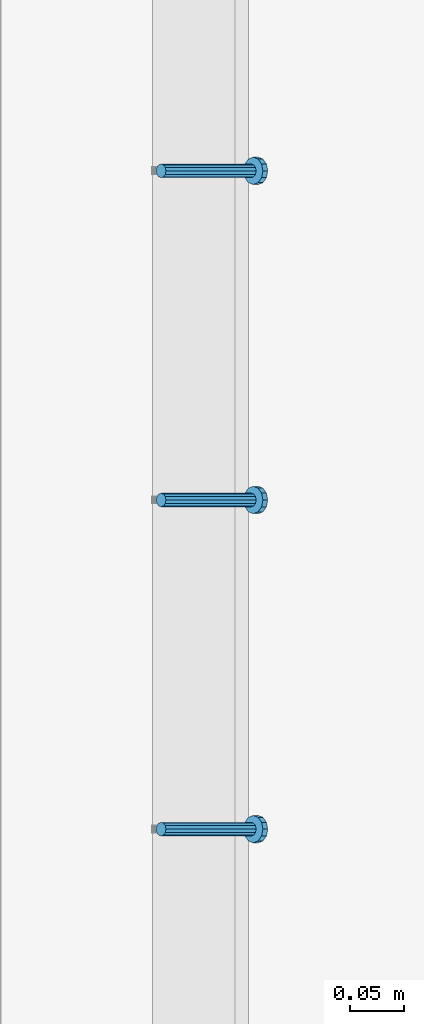
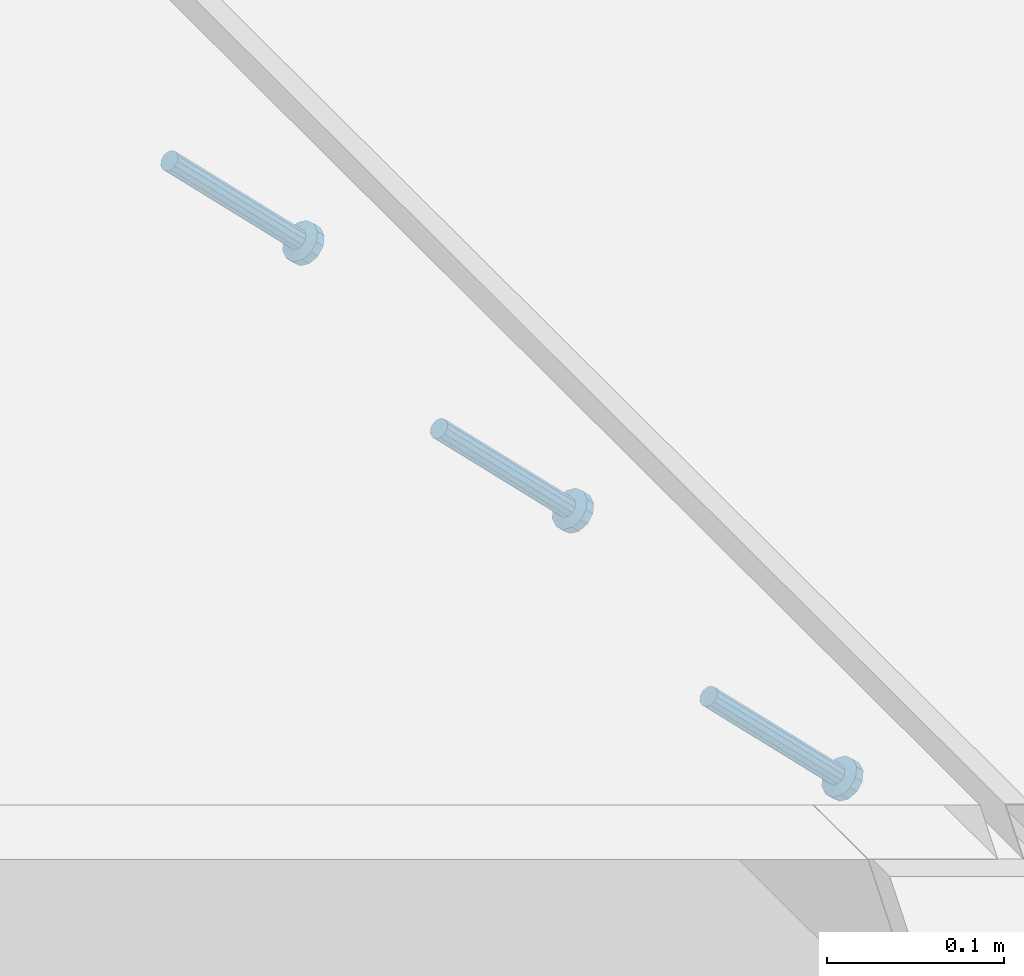
# One storey, part 2166 of 3843: 3 members, 1 element without a shape of its own.
"""IFC2X3 building model written with IfcOpenShell, lengths in millimetres."""

from ifc_helpers import new_model, si_unit, frame, origin_with_axes, place, context, subcontext, project, spatial, faceted_brep, material, type_object, element, aggregate, save


model = new_model("IFC2X3")

# Units and contexts
model_context = context("Model", 3, precision=1e-05, world=origin_with_axes())
body_context = subcontext(model_context, "Body", "Model", "MODEL_VIEW")
ifc_project = project(units=[si_unit("LENGTHUNIT", "METRE", prefix="MILLI"), si_unit("AREAUNIT", "SQUARE_METRE"), si_unit("VOLUMEUNIT", "CUBIC_METRE"), si_unit("MASSUNIT", "GRAM", prefix="KILO"), si_unit("TIMEUNIT", "SECOND"), si_unit("PLANEANGLEUNIT", "RADIAN"), si_unit("SOLIDANGLEUNIT", "STERADIAN"), si_unit("THERMODYNAMICTEMPERATUREUNIT", "DEGREE_CELSIUS"), si_unit("LUMINOUSINTENSITYUNIT", "LUMEN")], contexts=[model_context])

# Site, building, storey
site_placement = place(None, origin_with_axes())
site = spatial("IfcSite", under=ifc_project, at=site_placement, CompositionType="ELEMENT")
building_placement = place(site_placement, origin_with_axes())
building = spatial("IfcBuilding", under=site, at=building_placement, Name="Undefined", CompositionType="ELEMENT")
storey_placement = place(building_placement, origin_with_axes())
storey = spatial("IfcBuildingStorey", under=building, at=storey_placement, Name="Undefined", CompositionType="ELEMENT", Elevation=0.0)

# Assembly, members
assembly_placement = place(storey_placement, origin_with_axes())
assembly = element("IfcElementAssembly", 1, at=assembly_placement, inside=storey, Name="EMBED_ANGLE", AssemblyPlace="NOTDEFINED", PredefinedType="RIGID_FRAME")
ifc_material = material(Name="STEEL/A108")
member_type = type_object("IfcMemberType", PredefinedType="NOTDEFINED")
member_1_placement = place(assembly_placement, frame((66677.3495, 31102.4271953125, 30446.6625), z_axis=(0.0, 1.0, 0.0), x_axis=(0.707106781186548, 0.0, -0.707106781186548)))
member_1 = element("IfcMember", 2, at=member_1_placement, type_object=member_type, material=ifc_material, Name="HEADED STUD ANCHOR", context=body_context, shape_type="Brep", body=[
    faceted_brep([(7.27595761418343e-12, -3.18000006675175, 5.5), (0.0, -5.49999999998363, 3.1800000667572), (118.110000000976, -5.49999999999091, 3.1800000667572), (118.110000000983, -3.18000006675175, 5.5), (0.0, -6.3499999046162, 0.0), (118.110000000968, -6.34999990461256, 0.0), (0.0, -5.49999999998363, -3.1800000667572), (118.110000000976, -5.49999999999091, -3.1800000667572), (7.27595761418343e-12, -3.18000006675175, -5.5), (118.110000000983, -3.18000006675175, -5.5), (7.27595761418343e-12, -1.81898940354586e-12, -6.34999990463257), (118.110000000968, -1.81898940354586e-12, -6.34999990463257), (0.0, 3.18000006675175, -5.5), (118.110000000968, 3.18000006674811, -5.5), (7.27595761418343e-12, 5.49999999998363, -3.1800000667572), (118.110000000983, 5.49999999998363, -3.1800000667572), (7.27595761418343e-12, 6.3499999046162, 0.0), (118.110000000976, 6.34999990461256, 0.0), (7.27595761418343e-12, 5.49999999998363, 3.1800000667572), (118.110000000983, 5.49999999998363, 3.1800000667572), (0.0, 3.18000006675175, 5.5), (118.110000000968, 3.18000006674811, 5.5), (7.27595761418343e-12, -1.81898940354586e-12, 6.34999990463257), (118.110000000968, -1.81898940354586e-12, 6.34999990463257), (120.650000000991, -10.9899997710909, 6.34999990463257), (120.650000000998, -6.34000015257152, 10.9899997711182), (120.650000000991, -12.6999998092379, 0.0), (120.650000000991, -10.9899997710909, -6.34999990463257), (120.650000000998, -6.34000015257152, -10.9899997711182), (120.650000000991, -1.81898940354586e-12, -12.6899995803833), (120.650000000991, 6.34000015257152, -10.9899997711182), (120.650000000998, 10.9899997710909, -6.34999990463257), (120.650000000991, 12.6999998092342, 0.0), (120.650000000998, 10.9899997710909, 6.34999990463257), (120.650000000991, 6.34000015257152, 10.9899997711182), (120.650000000991, -1.81898940354586e-12, 12.6899995803833), (127.000000001048, -10.9899997710945, 6.34999990463257), (127.000000001048, -6.34000015257152, 10.9899997711182), (127.000000001048, -12.6999998092342, 0.0), (127.000000001048, -10.9899997710945, -6.34999990463257), (127.000000001048, -6.34000015257152, -10.9899997711182), (127.000000001048, 1.81898940354586e-12, -12.6899995803833), (127.000000001048, 6.34000015256788, -10.9899997711182), (127.000000001048, 10.9899997710909, -6.34999990463257), (127.000000001048, 12.6999998092379, 0.0), (127.000000001048, 10.9899997710909, 6.34999990463257), (127.000000001048, 6.34000015256788, 10.9899997711182), (127.000000001048, 1.81898940354586e-12, 12.6899995803833)], [[[0, 1, 2, 3]], [[1, 4, 5, 2]], [[4, 6, 7, 5]], [[6, 8, 9, 7]], [[8, 10, 11, 9]], [[10, 12, 13, 11]], [[12, 14, 15, 13]], [[14, 16, 17, 15]], [[16, 18, 19, 17]], [[18, 20, 21, 19]], [[20, 22, 23, 21]], [[22, 0, 3, 23]], [[22, 20, 18, 16, 14, 12, 10, 8, 6, 4, 1, 0]], [[3, 2, 24, 25]], [[2, 5, 26, 24]], [[5, 7, 27, 26]], [[7, 9, 28, 27]], [[9, 11, 29, 28]], [[11, 13, 30, 29]], [[13, 15, 31, 30]], [[15, 17, 32, 31]], [[17, 19, 33, 32]], [[19, 21, 34, 33]], [[21, 23, 35, 34]], [[23, 3, 25, 35]], [[25, 24, 36, 37]], [[24, 26, 38, 36]], [[26, 27, 39, 38]], [[27, 28, 40, 39]], [[28, 29, 41, 40]], [[29, 30, 42, 41]], [[30, 31, 43, 42]], [[31, 32, 44, 43]], [[32, 33, 45, 44]], [[33, 34, 46, 45]], [[34, 35, 47, 46]], [[35, 25, 37, 47]], [[38, 39, 40, 41, 42, 43, 44, 45, 46, 47, 37, 36]]]),
])
member_2_placement = place(assembly_placement, frame((66677.3495, 31407.2271953125, 30446.6625), z_axis=(0.0, 1.0, 0.0), x_axis=(0.707106781186548, 0.0, -0.707106781186548)))
member_2 = element("IfcMember", 3, at=member_2_placement, type_object=member_type, material=ifc_material, Name="HEADED STUD ANCHOR", context=body_context, shape_type="Brep", body=[
    faceted_brep([(7.27595761418343e-12, -3.18000006675175, 5.5), (0.0, -5.49999999998363, 3.1800000667572), (118.110000000976, -5.49999999999091, 3.1800000667572), (118.110000000983, -3.18000006675175, 5.5), (0.0, -6.3499999046162, 0.0), (118.110000000968, -6.34999990461256, 0.0), (0.0, -5.49999999998363, -3.1800000667572), (118.110000000976, -5.49999999999091, -3.1800000667572), (7.27595761418343e-12, -3.18000006675175, -5.5), (118.110000000983, -3.18000006675175, -5.5), (7.27595761418343e-12, -1.81898940354586e-12, -6.34999990463257), (118.110000000968, -1.81898940354586e-12, -6.34999990463257), (0.0, 3.18000006675175, -5.5), (118.110000000968, 3.18000006674811, -5.5), (7.27595761418343e-12, 5.49999999998363, -3.1800000667572), (118.110000000983, 5.49999999998363, -3.1800000667572), (7.27595761418343e-12, 6.3499999046162, 0.0), (118.110000000976, 6.34999990461256, 0.0), (7.27595761418343e-12, 5.49999999998363, 3.1800000667572), (118.110000000983, 5.49999999998363, 3.1800000667572), (0.0, 3.18000006675175, 5.5), (118.110000000968, 3.18000006674811, 5.5), (7.27595761418343e-12, -1.81898940354586e-12, 6.34999990463257), (118.110000000968, -1.81898940354586e-12, 6.34999990463257), (120.650000000991, -10.9899997710909, 6.34999990463257), (120.650000000998, -6.34000015257152, 10.9899997711182), (120.650000000991, -12.6999998092379, 0.0), (120.650000000991, -10.9899997710909, -6.34999990463257), (120.650000000998, -6.34000015257152, -10.9899997711182), (120.650000000991, -1.81898940354586e-12, -12.6899995803833), (120.650000000991, 6.34000015257152, -10.9899997711182), (120.650000000998, 10.9899997710909, -6.34999990463257), (120.650000000991, 12.6999998092342, 0.0), (120.650000000998, 10.9899997710909, 6.34999990463257), (120.650000000991, 6.34000015257152, 10.9899997711182), (120.650000000991, -1.81898940354586e-12, 12.6899995803833), (127.000000001048, -10.9899997710945, 6.34999990463257), (127.000000001048, -6.34000015257152, 10.9899997711182), (127.000000001048, -12.6999998092342, 0.0), (127.000000001048, -10.9899997710945, -6.34999990463257), (127.000000001048, -6.34000015257152, -10.9899997711182), (127.000000001048, 1.81898940354586e-12, -12.6899995803833), (127.000000001048, 6.34000015256788, -10.9899997711182), (127.000000001048, 10.9899997710909, -6.34999990463257), (127.000000001048, 12.6999998092379, 0.0), (127.000000001048, 10.9899997710909, 6.34999990463257), (127.000000001048, 6.34000015256788, 10.9899997711182), (127.000000001048, 1.81898940354586e-12, 12.6899995803833)], [[[0, 1, 2, 3]], [[1, 4, 5, 2]], [[4, 6, 7, 5]], [[6, 8, 9, 7]], [[8, 10, 11, 9]], [[10, 12, 13, 11]], [[12, 14, 15, 13]], [[14, 16, 17, 15]], [[16, 18, 19, 17]], [[18, 20, 21, 19]], [[20, 22, 23, 21]], [[22, 0, 3, 23]], [[22, 20, 18, 16, 14, 12, 10, 8, 6, 4, 1, 0]], [[3, 2, 24, 25]], [[2, 5, 26, 24]], [[5, 7, 27, 26]], [[7, 9, 28, 27]], [[9, 11, 29, 28]], [[11, 13, 30, 29]], [[13, 15, 31, 30]], [[15, 17, 32, 31]], [[17, 19, 33, 32]], [[19, 21, 34, 33]], [[21, 23, 35, 34]], [[23, 3, 25, 35]], [[25, 24, 36, 37]], [[24, 26, 38, 36]], [[26, 27, 39, 38]], [[27, 28, 40, 39]], [[28, 29, 41, 40]], [[29, 30, 42, 41]], [[30, 31, 43, 42]], [[31, 32, 44, 43]], [[32, 33, 45, 44]], [[33, 34, 46, 45]], [[34, 35, 47, 46]], [[35, 25, 37, 47]], [[38, 39, 40, 41, 42, 43, 44, 45, 46, 47, 37, 36]]]),
])
member_3_placement = place(assembly_placement, frame((66677.3495, 31712.0271953125, 30446.6625), z_axis=(0.0, 1.0, 0.0), x_axis=(0.707106781186548, 0.0, -0.707106781186548)))
member_3 = element("IfcMember", 4, at=member_3_placement, type_object=member_type, material=ifc_material, Name="HEADED STUD ANCHOR", context=body_context, shape_type="Brep", body=[
    faceted_brep([(7.27595761418343e-12, -3.18000006675175, 5.5), (0.0, -5.49999999998363, 3.1800000667572), (118.110000000976, -5.49999999999091, 3.1800000667572), (118.110000000983, -3.18000006675175, 5.5), (0.0, -6.3499999046162, 0.0), (118.110000000968, -6.34999990461256, 0.0), (0.0, -5.49999999998363, -3.1800000667572), (118.110000000976, -5.49999999999091, -3.1800000667572), (7.27595761418343e-12, -3.18000006675175, -5.5), (118.110000000983, -3.18000006675175, -5.5), (7.27595761418343e-12, -1.81898940354586e-12, -6.34999990463257), (118.110000000968, -1.81898940354586e-12, -6.34999990463257), (0.0, 3.18000006675175, -5.5), (118.110000000968, 3.18000006674811, -5.5), (7.27595761418343e-12, 5.49999999998363, -3.1800000667572), (118.110000000983, 5.49999999998363, -3.1800000667572), (7.27595761418343e-12, 6.3499999046162, 0.0), (118.110000000976, 6.34999990461256, 0.0), (7.27595761418343e-12, 5.49999999998363, 3.1800000667572), (118.110000000983, 5.49999999998363, 3.1800000667572), (0.0, 3.18000006675175, 5.5), (118.110000000968, 3.18000006674811, 5.5), (7.27595761418343e-12, -1.81898940354586e-12, 6.34999990463257), (118.110000000968, -1.81898940354586e-12, 6.34999990463257), (120.650000000991, -10.9899997710909, 6.34999990463257), (120.650000000998, -6.34000015257152, 10.9899997711182), (120.650000000991, -12.6999998092379, 0.0), (120.650000000991, -10.9899997710909, -6.34999990463257), (120.650000000998, -6.34000015257152, -10.9899997711182), (120.650000000991, -1.81898940354586e-12, -12.6899995803833), (120.650000000991, 6.34000015257152, -10.9899997711182), (120.650000000998, 10.9899997710909, -6.34999990463257), (120.650000000991, 12.6999998092342, 0.0), (120.650000000998, 10.9899997710909, 6.34999990463257), (120.650000000991, 6.34000015257152, 10.9899997711182), (120.650000000991, -1.81898940354586e-12, 12.6899995803833), (127.000000001048, -10.9899997710945, 6.34999990463257), (127.000000001048, -6.34000015257152, 10.9899997711182), (127.000000001048, -12.6999998092342, 0.0), (127.000000001048, -10.9899997710945, -6.34999990463257), (127.000000001048, -6.34000015257152, -10.9899997711182), (127.000000001048, 1.81898940354586e-12, -12.6899995803833), (127.000000001048, 6.34000015256788, -10.9899997711182), (127.000000001048, 10.9899997710909, -6.34999990463257), (127.000000001048, 12.6999998092379, 0.0), (127.000000001048, 10.9899997710909, 6.34999990463257), (127.000000001048, 6.34000015256788, 10.9899997711182), (127.000000001048, 1.81898940354586e-12, 12.6899995803833)], [[[0, 1, 2, 3]], [[1, 4, 5, 2]], [[4, 6, 7, 5]], [[6, 8, 9, 7]], [[8, 10, 11, 9]], [[10, 12, 13, 11]], [[12, 14, 15, 13]], [[14, 16, 17, 15]], [[16, 18, 19, 17]], [[18, 20, 21, 19]], [[20, 22, 23, 21]], [[22, 0, 3, 23]], [[22, 20, 18, 16, 14, 12, 10, 8, 6, 4, 1, 0]], [[3, 2, 24, 25]], [[2, 5, 26, 24]], [[5, 7, 27, 26]], [[7, 9, 28, 27]], [[9, 11, 29, 28]], [[11, 13, 30, 29]], [[13, 15, 31, 30]], [[15, 17, 32, 31]], [[17, 19, 33, 32]], [[19, 21, 34, 33]], [[21, 23, 35, 34]], [[23, 3, 25, 35]], [[25, 24, 36, 37]], [[24, 26, 38, 36]], [[26, 27, 39, 38]], [[27, 28, 40, 39]], [[28, 29, 41, 40]], [[29, 30, 42, 41]], [[30, 31, 43, 42]], [[31, 32, 44, 43]], [[32, 33, 45, 44]], [[33, 34, 46, 45]], [[34, 35, 47, 46]], [[35, 25, 37, 47]], [[38, 39, 40, 41, 42, 43, 44, 45, 46, 47, 37, 36]]]),
])
aggregate(assembly, [member_1, member_2, member_3])

save(model, "model.ifc")
